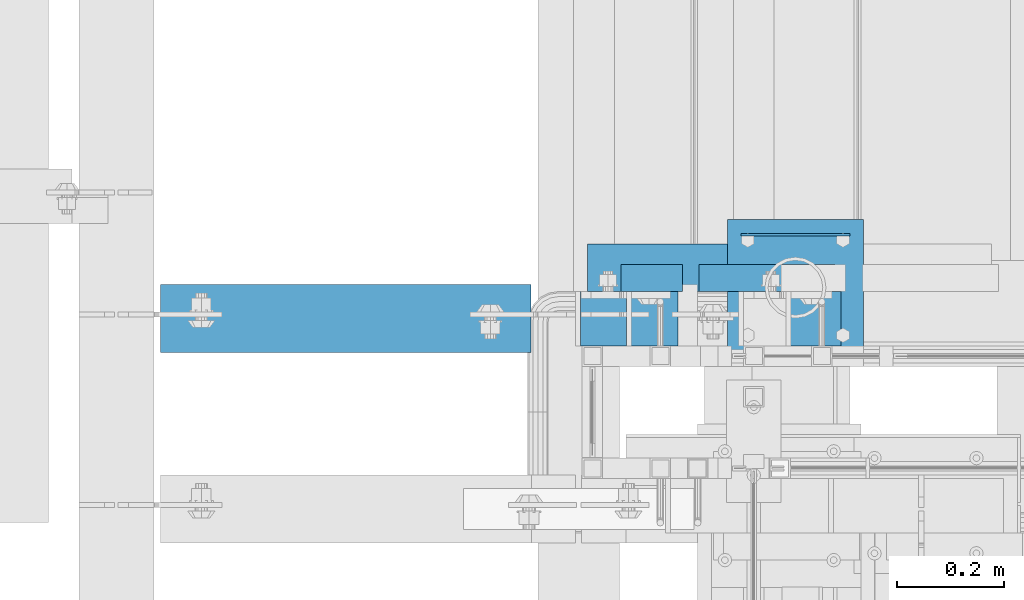
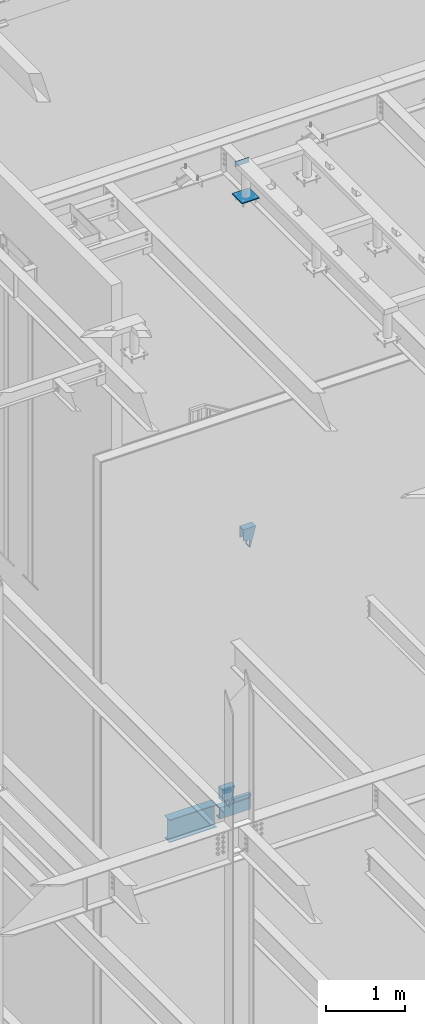
# One storey, part 930 of 1179: 9 beams, 4 elements without a shape of their own.
"""IFC2X3 building model written with IfcOpenShell, lengths in millimetres."""

from ifc_helpers import new_model, si_unit, frame, origin_with_axes, place, context, subcontext, project, spatial, faceted_brep, material, type_object, element, aggregate, save


model = new_model("IFC2X3")

# Units and contexts
model_context = context("Model", 3, precision=1e-05, world=origin_with_axes())
body_context = subcontext(model_context, "Body", "Model", "MODEL_VIEW")
ifc_project = project(units=[si_unit("LENGTHUNIT", "METRE", prefix="MILLI"), si_unit("AREAUNIT", "SQUARE_METRE"), si_unit("VOLUMEUNIT", "CUBIC_METRE"), si_unit("MASSUNIT", "GRAM", prefix="KILO"), si_unit("TIMEUNIT", "SECOND"), si_unit("PLANEANGLEUNIT", "RADIAN"), si_unit("SOLIDANGLEUNIT", "STERADIAN"), si_unit("THERMODYNAMICTEMPERATUREUNIT", "DEGREE_CELSIUS"), si_unit("LUMINOUSINTENSITYUNIT", "LUMEN")], contexts=[model_context])

# Site, building, storey
site_placement = place(None, origin_with_axes())
site = spatial("IfcSite", under=ifc_project, at=site_placement, CompositionType="ELEMENT")
building_placement = place(site_placement, origin_with_axes())
building = spatial("IfcBuilding", under=site, at=building_placement, Name="Undefined", CompositionType="ELEMENT")
storey_placement = place(building_placement, origin_with_axes())
storey = spatial("IfcBuildingStorey", under=building, at=storey_placement, Name="Undefined", CompositionType="ELEMENT", Elevation=0.0)

# Assembly, beams
assembly_1_placement = place(storey_placement, origin_with_axes())
assembly_1 = element("IfcElementAssembly", 1, at=assembly_1_placement, inside=storey, Name="STAIR", AssemblyPlace="NOTDEFINED", PredefinedType="RIGID_FRAME")
ifc_material_1 = material(Name="STEEL/A36")
beam_type_1 = type_object("IfcBeamType", Name="L2X2X3/16", PredefinedType="NOTDEFINED")
beam_1_placement = place(assembly_1_placement, frame((19472.275009742, 39827.2000000469, 4156.67031471884), z_axis=(0.0, 1.0, 0.0), x_axis=(-0.999999999996761, 0.0, -2.5449999982255e-06)))
beam_1 = element("IfcBeam", 2, at=beam_1_placement, type_object=beam_type_1, material=ifc_material_1, Name="ANGLE", ObjectType="L2X2X3/16", context=body_context, shape_type="Brep", body=[
    faceted_brep([(0.0, 25.3999999999996, -25.4000000000015), (0.0, 25.3999999999996, 25.4000000000015), (114.300000000865, 25.3999999999633, 25.4000000000015), (114.300000000865, 25.3999999999633, -25.4000000000015), (0.0, 20.6374999999998, 25.4000000000015), (114.300000000861, 20.6374999999634, 25.4000000000015), (0.0, 20.6374999999998, -20.6374999999971), (114.300000000861, 20.6374999999634, -20.6374999999971), (0.0, -25.3999999999996, -20.6374999999971), (114.300000000847, -25.4000000000333, -20.6374999999971), (0.0, -25.3999999999996, -25.4000000000015), (114.300000000847, -25.4000000000333, -25.4000000000015)], [[[0, 1, 2, 3]], [[1, 4, 5, 2]], [[4, 6, 7, 5]], [[6, 8, 9, 7]], [[8, 10, 11, 9]], [[10, 0, 3, 11]], [[5, 7, 9, 11, 3, 2]], [[10, 8, 6, 4, 1, 0]]]),
])
beam_2_placement = place(assembly_1_placement, frame((19757.632173537, 39827.2000000469, 3980.19321612135), z_axis=(0.0, 1.0, 0.0), x_axis=(-1.0, 0.0, 0.0)))
beam_2 = element("IfcBeam", 3, at=beam_2_placement, type_object=beam_type_1, material=ifc_material_1, Name="ANGLE", ObjectType="L2X2X3/16", context=body_context, shape_type="Brep", body=[
    faceted_brep([(0.0, 25.3999999999996, -25.4000000000015), (0.0, 25.3999999999996, 25.4000000000015), (254.0, 25.3999999999996, 25.4000000000001), (254.0, 25.3999999999996, -25.4000000000001), (0.0, 20.6374999999998, 25.4000000000015), (254.0, 20.6374999999998, 25.4000000000001), (0.0, 20.6374999999998, -20.6374999999971), (254.0, 20.6374999999998, -20.6374999999998), (0.0, -25.3999999999996, -20.6374999999971), (254.0, -25.3999999999996, -20.6374999999998), (0.0, -25.3999999999996, -25.4000000000015), (254.0, -25.3999999999996, -25.4000000000001)], [[[0, 1, 2, 3]], [[1, 4, 5, 2]], [[4, 6, 7, 5]], [[6, 8, 9, 7]], [[8, 10, 11, 9]], [[10, 0, 3, 11]], [[5, 7, 9, 11, 3, 2]], [[10, 8, 6, 4, 1, 0]]]),
])

# Assembly, beam
assembly_2_placement = place(storey_placement, origin_with_axes())
assembly_2 = element("IfcElementAssembly", 4, at=assembly_2_placement, inside=storey, Name="FRAME", AssemblyPlace="NOTDEFINED", PredefinedType="RIGID_FRAME")
beam_type_2 = type_object("IfcBeamType", PredefinedType="NOTDEFINED")
beam_3_placement = place(assembly_2_placement, frame((19581.8125, 39908.2415542222, 13722.35), z_axis=(0.0, 0.0, 1.0), x_axis=(1.0, 0.0, 0.0)))
beam_3 = element("IfcBeam", 5, at=beam_3_placement, type_object=beam_type_2, material=ifc_material_1, Name="PLATE", context=body_context, shape_type="Brep", body=[
    faceted_brep([(0.0, 2.38149999999951, -38.0999999999985), (0.0, 2.38149999999951, 38.0999999999985), (203.199999999997, 2.38150000000314, 38.1000000000004), (203.199999999997, 2.38150000000314, -38.1000000000004), (0.0, -2.38149999999951, 38.0999999999985), (203.199999999997, -2.38150000000314, 38.1000000000004), (0.0, -2.38149999999951, -38.0999999999985), (203.199999999997, -2.38150000000314, -38.1000000000004)], [[[0, 1, 2, 3]], [[1, 4, 5, 2]], [[4, 6, 7, 5]], [[6, 0, 3, 7]], [[5, 7, 3, 2]], [[6, 4, 1, 0]]]),
])

assembly_3_placement = place(storey_placement, origin_with_axes())
assembly_3 = element("IfcElementAssembly", 6, at=assembly_3_placement, inside=storey, Name="BEAM", AssemblyPlace="NOTDEFINED", PredefinedType="RIGID_FRAME")
ifc_material_2 = material(Name="STEEL/A992")
beam_type_3 = type_object("IfcBeamType", Name="W14X22", PredefinedType="NOTDEFINED")
beam_4_placement = place(assembly_3_placement, frame((18415.0, 39751.000000021, 3927.475), z_axis=(0.0, 0.0, 1.0), x_axis=(1.0, 0.0, 0.0)))
beam_4 = element("IfcBeam", 7, at=beam_4_placement, type_object=beam_type_3, material=ifc_material_2, Name="BEAM", ObjectType="W14X22", context=body_context, shape_type="Brep", body=[
    faceted_brep([(82.5499999999993, -63.5, -174.625), (82.5499999999993, 63.5, -174.625), (774.700000000001, 63.5, -174.625), (774.700000000001, -63.5, -174.625), (82.5499999999993, -63.5, -166.6875), (82.5499999999993, -3.17500000000291, -166.6875), (82.5499999999993, -3.17500000000291, 166.6875), (82.5499999999993, -63.5, 166.6875), (82.5499999999993, -63.5, 174.625), (82.5499999999993, 63.5, 174.625), (82.5499999999993, 63.5, 166.6875), (82.5499999999993, 3.17500000000291, 166.6875), (82.5499999999993, 3.17500000000291, 137.265000000114), (82.5499999999993, 3.17500000000291, -92.8149999999623), (82.5499999999993, 3.17500000000291, -166.6875), (82.5499999999993, 63.5, -166.6875), (774.700000000001, -63.5, -166.6875), (774.700000000001, -3.17500000000291, -166.6875), (774.700000000001, -3.17500000000291, 166.6875), (774.700000000001, -63.5, 166.6875), (774.700000000001, -63.5, 174.625), (774.700000000001, 63.5, 174.625), (774.700000000001, 63.5, 166.6875), (774.700000000001, 3.17500000000291, 166.6875), (774.700000000001, 3.17500000000291, 137.265000000132), (774.700000000001, 3.17500000000291, -92.8149999999441), (774.700000000001, 3.17500000000291, -166.6875), (774.700000000001, 63.5, -166.6875)], [[[0, 1, 2, 3]], [[0, 4, 5, 6, 7, 8, 9, 10, 11, 12, 13, 14, 15, 1]], [[5, 4, 16, 17]], [[6, 5, 17, 18]], [[7, 6, 18, 19]], [[8, 7, 19, 20]], [[9, 8, 20, 21]], [[10, 9, 21, 22]], [[11, 10, 22, 23]], [[14, 13, 12, 11, 23, 24, 25, 26]], [[15, 14, 26, 27]], [[1, 15, 27, 2]], [[26, 25, 24, 23, 22, 21, 20, 19, 18, 17, 16, 3, 2, 27]], [[4, 0, 3, 16]]]),
])
aggregate(assembly_3, [beam_4])

# Beam
beam_type_4 = type_object("IfcBeamType", Name="MC7X19.1", PredefinedType="NOTDEFINED")
beam_5_placement = place(assembly_1_placement, frame((19295.26875, 39846.2500000474, 3855.77291612159), z_axis=(0.0, 0.0, -1.0), x_axis=(1.0, 0.0, 0.0)))
beam_5 = element("IfcBeam", 8, at=beam_5_placement, type_object=beam_type_4, material=ifc_material_1, Name="BEAM", ObjectType="MC7X19.1", context=body_context, shape_type="Brep", body=[
    faceted_brep([(0.0, 44.4499999999971, -88.9000000000001), (0.0, 44.4499999999971, 88.9000000000001), (449.291786109603, 44.4499999999971, 88.9000000000001), (449.291786109603, 44.4499999999971, -88.9000000000001), (0.0, -44.4499999999971, 88.9000000000001), (449.291786109603, -44.4499999999971, 88.9000000000001), (0.0, -44.4499999999971, 77.0845549999999), (449.291786109603, -44.4499999999971, 77.0845549999999), (0.0, 34.9250000000029, 75.5049924999998), (449.291786109603, 34.9250000000029, 75.5049924999998), (0.0, 34.9250000000029, -75.5049924999998), (449.291786109603, 34.9250000000029, -75.5049924999998), (0.0, -44.4499999999971, -77.0845549999999), (449.291786109603, -44.4499999999971, -77.0845549999999), (0.0, -44.4499999999971, -88.9000000000001), (449.291786109603, -44.4499999999971, -88.9000000000001)], [[[0, 1, 2, 3]], [[1, 4, 5, 2]], [[4, 6, 7, 5]], [[6, 8, 9, 7]], [[8, 10, 11, 9]], [[10, 12, 13, 11]], [[12, 14, 15, 13]], [[14, 0, 3, 15]], [[5, 7, 9, 11, 13, 15, 3, 2]], [[14, 12, 10, 8, 6, 4, 1, 0]]]),
])

beam_type_5 = type_object("IfcBeamType", PredefinedType="NOTDEFINED")
beam_6_placement = place(assembly_1_placement, frame((19367.49999946, 39751.0000000355, 4106.86249999621), z_axis=(0.0, -1.0, 0.0), x_axis=(-1.0, 0.0, 0.0)))
beam_6 = element("IfcBeam", 9, at=beam_6_placement, type_object=beam_type_5, material=ifc_material_1, Name="PLATE", context=body_context, shape_type="Brep", body=[
    faceted_brep([(0.0, 4.76249999999982, -50.7999999999993), (0.0, 4.76249999999982, 50.7999999999993), (85.7249992897196, 4.76249999999982, 50.8000000000029), (85.7249992897196, 4.76249999999982, -50.8000000000029), (0.0, -4.76249999999982, 50.7999999999993), (85.7249992897196, -4.76249999999982, 50.8000000000029), (0.0, -4.76249999999982, -50.7999999999993), (85.7249992897196, -4.76249999999982, -50.8000000000029)], [[[0, 1, 2, 3]], [[1, 4, 5, 2]], [[4, 6, 7, 5]], [[6, 0, 3, 7]], [[5, 7, 3, 2]], [[6, 4, 1, 0]]]),
])

ifc_material_3 = material()
beam_type_6 = type_object("IfcBeamType", Name="HSS12X4X3/8", PredefinedType="NOTDEFINED")
beam_7_placement = place(assembly_1_placement, frame((19281.7750004224, 39751.0000000151, 4133.84999940475), z_axis=(0.0, 0.0, 1.0), x_axis=(1.0, 0.0, 0.0)))
beam_7 = element("IfcBeam", 10, at=beam_7_placement, type_object=beam_type_6, material=ifc_material_3, Name="STAIR", ObjectType="HSS12X4X3/8", context=body_context, shape_type="Brep", body=[
    faceted_brep([(0.0, 41.2750000000015, -22.2249994143422), (0.0, 50.8000000000029, -22.2249994143422), (95.249998907173, 50.8000000000029, -22.2249994143522), (95.249998907173, 41.2750000000015, -22.2249994143522), (95.249998907173, -50.8000000000029, -22.2249994143522), (95.249998907173, -41.2750000000015, -22.2249994143522), (95.2499988966483, -41.2750000000015, -142.875), (95.2499988966483, 41.2750000000015, -142.875), (95.2499988958189, 50.8000000000029, -152.4), (95.2499988958189, -50.8000000000029, -152.4), (0.0, -50.8000000000029, -22.2249994143422), (0.0, -41.2750000000015, -22.2249994143422), (0.0, 50.8000000000029, 152.4), (0.0, -50.8000000000029, 152.4), (182.028405919682, -50.8000000000029, 152.4), (182.028405919682, 50.8000000000029, 152.4), (100.156350391899, 50.8000000000029, -152.4), (100.156350391899, -50.8000000000029, -152.4), (179.46990418444, -41.2750000000015, 142.875), (179.46990418444, 41.2750000000015, 142.875), (102.714852127141, 41.2750000000015, -142.875), (102.714852127141, -41.2750000000015, -142.875), (0.0, -41.2750000000015, 142.875), (0.0, 41.2750000000015, 142.875)], [[[0, 1, 2, 3]], [[4, 5, 6, 7, 3, 2, 8, 9]], [[10, 11, 5, 4]], [[12, 13, 14, 15]], [[16, 17, 9, 8]], [[12, 15, 16, 8, 2, 1]], [[14, 17, 16, 15], [18, 19, 20, 21]], [[22, 23, 19, 18]], [[20, 19, 23, 0, 3, 7]], [[21, 20, 7, 6]], [[22, 18, 21, 6, 5, 11]], [[13, 12, 1, 0, 23, 22, 11, 10]], [[17, 14, 13, 10, 4, 9]]]),
])

aggregate(assembly_1, [beam_1, beam_2, beam_6, beam_7, beam_5])

# Assembly, beam
assembly_4_placement = place(storey_placement, origin_with_axes())
assembly_4 = element("IfcElementAssembly", 11, at=assembly_4_placement, inside=storey, Name="STAIR", AssemblyPlace="NOTDEFINED", PredefinedType="RIGID_FRAME")
beam_8_placement = place(assembly_4_placement, frame((19586.5750027853, 39751.0000000182, 8045.45000000882), z_axis=(0.0, 0.0, 1.0), x_axis=(1.0, 0.0, 0.0)))
beam_8 = element("IfcBeam", 12, at=beam_8_placement, type_object=beam_type_6, material=ifc_material_3, Name="STAIR", ObjectType="HSS12X4X3/8", context=body_context, shape_type="Brep", body=[
    faceted_brep([(0.0, 41.2750000000015, -22.2249994143422), (0.0, 50.8000000000029, -22.2249994143422), (88.8999947435514, 50.8000000000029, -22.2250001796274), (88.8999947435514, 41.2750000000015, -22.2250001796274), (88.8999947435514, -50.8000000000029, -22.2250001796274), (88.8999947435514, -41.2750000000015, -22.2250001796274), (88.9000144094352, -41.2750000000015, -142.875), (88.9000144094352, 41.2750000000015, -142.875), (88.9000159620045, 50.8000000000029, -152.4), (88.9000159620045, -50.8000000000029, -152.4), (0.0, -50.8000000000029, -22.2249994143422), (0.0, -41.2750000000015, -22.2249994143422), (0.0, 50.8000000000029, 152.4), (0.0, -50.8000000000029, 152.4), (182.399011069894, -50.8000000000029, 152.4), (182.399011069894, 50.8000000000029, 152.4), (99.9965924996395, 50.8000000000029, -152.4), (99.9965924996395, -50.8000000000029, -152.4), (179.823935489574, -41.2750000000015, 142.875), (179.823935489574, 41.2750000000015, 142.875), (102.57166807996, 41.2750000000015, -142.875), (102.57166807996, -41.2750000000015, -142.875), (0.0, -41.2750000000015, 142.875), (0.0, 41.2750000000015, 142.875)], [[[0, 1, 2, 3]], [[4, 5, 6, 7, 3, 2, 8, 9]], [[10, 11, 5, 4]], [[12, 13, 14, 15]], [[16, 17, 9, 8]], [[12, 15, 16, 8, 2, 1]], [[14, 17, 16, 15], [18, 19, 20, 21]], [[22, 23, 19, 18]], [[20, 19, 23, 0, 3, 7]], [[21, 20, 7, 6]], [[22, 18, 21, 6, 5, 11]], [[13, 12, 1, 0, 23, 22, 11, 10]], [[17, 14, 13, 10, 4, 9]]]),
])
aggregate(assembly_4, [beam_8])

# Beam
beam_type_7 = type_object("IfcBeamType", PredefinedType="NOTDEFINED")
beam_9_placement = place(assembly_2_placement, frame((19683.4125, 39682.0225542222, 13258.8), z_axis=(1.0, 0.0, 0.0), x_axis=(0.0, 1.0, 0.0)))
beam_9 = element("IfcBeam", 13, at=beam_9_placement, type_object=beam_type_7, material=ifc_material_1, Name="PLATE", context=body_context, shape_type="Brep", body=[
    faceted_brep([(0.0, 6.35000000000036, -127.0), (0.0, 6.34999999999854, 127.0), (254.0, 6.35000000000036, 127.0), (254.0, 6.35000000000036, -127.0), (0.0, -6.34999999999854, 127.0), (254.0, -6.35000000000036, 127.0), (0.0, -6.35000000000036, -127.0), (254.0, -6.35000000000036, -127.0)], [[[0, 1, 2, 3]], [[1, 4, 5, 2]], [[4, 6, 7, 5]], [[6, 0, 3, 7]], [[5, 7, 3, 2]], [[6, 4, 1, 0]]]),
])

aggregate(assembly_2, [beam_3, beam_9])

save(model, "model.ifc")
